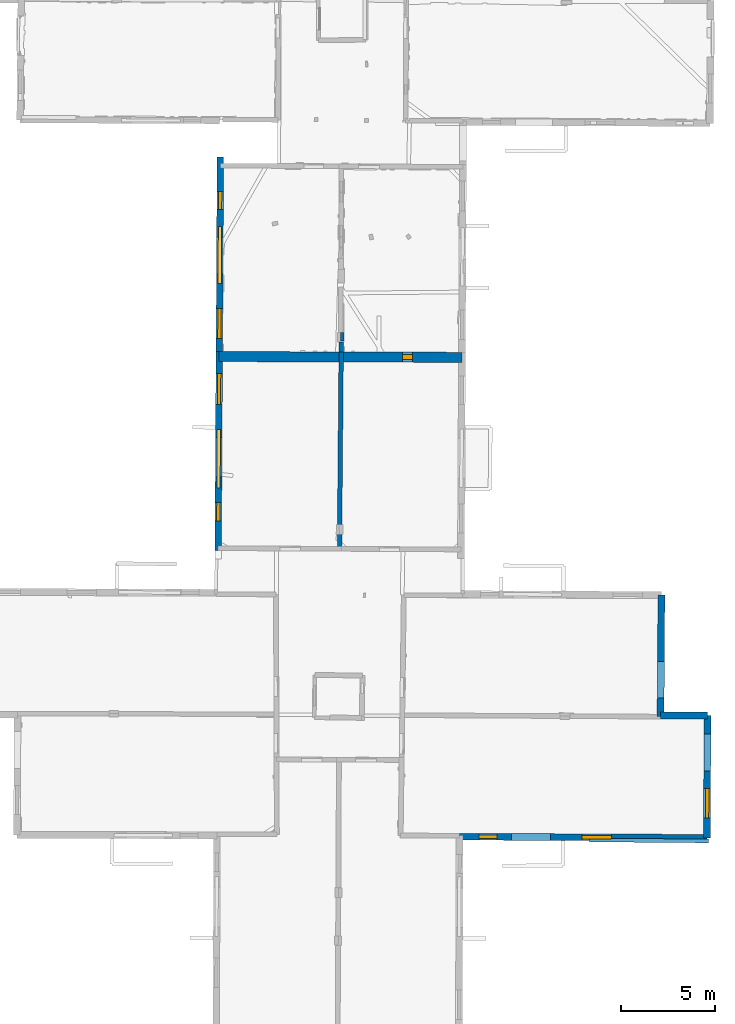
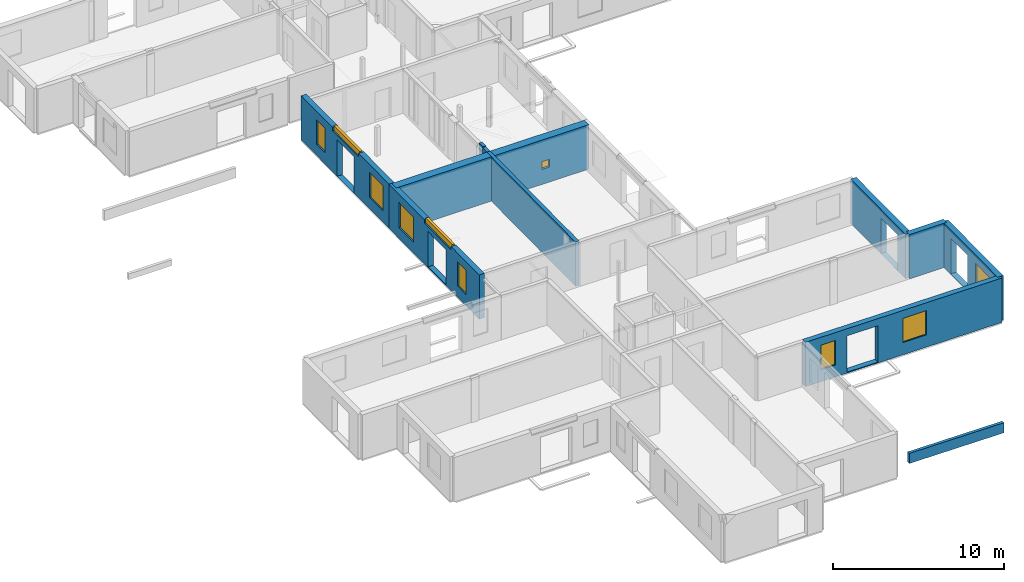
# One storey, part 6 of 17: 12 walls, 10 windows, 15 openings.
"""IFC2X3 building model written with IfcOpenShell, lengths in metres."""

from ifc_helpers import new_model, entity, si_unit, converted_unit, derived_unit, direction, frame, frame_2d, origin, origin_2d_with_axis, place, context, subcontext, project, spatial, polyline, rectangle, outline, extrude, source, transform, mapped, material, layer, layer_set, layer_usage, type_object, type_shapes, element, fill, save


model = new_model("IFC2X3")

# Units and contexts
model_context = context("Model", 3, precision=1e-05, world=origin(), true_north=direction((0.0, 1.0)))
body_context = subcontext(model_context, "Body", "Model", "MODEL_VIEW")
ifc_project = project(units=[si_unit("LENGTHUNIT", "METRE"), si_unit("AREAUNIT", "SQUARE_METRE"), si_unit("VOLUMEUNIT", "CUBIC_METRE"), converted_unit("PLANEANGLEUNIT", "DEGREE", entity("IfcRatioMeasure", 0.0174532925199433), si_unit("PLANEANGLEUNIT", "RADIAN"), dimensions=[0, 0, 0, 0, 0, 0, 0]), si_unit("MASSUNIT", "GRAM", prefix="KILO"), derived_unit("MASSDENSITYUNIT", [(si_unit("MASSUNIT", "GRAM", prefix="KILO"), 1), (si_unit("LENGTHUNIT", "METRE"), -3)]), derived_unit("MOMENTOFINERTIAUNIT", [(si_unit("LENGTHUNIT", "METRE"), 4)]), si_unit("TIMEUNIT", "SECOND"), si_unit("FREQUENCYUNIT", "HERTZ"), si_unit("THERMODYNAMICTEMPERATUREUNIT", "DEGREE_CELSIUS"), derived_unit("THERMALTRANSMITTANCEUNIT", [(si_unit("MASSUNIT", "GRAM", prefix="KILO"), 1), (si_unit("THERMODYNAMICTEMPERATUREUNIT", "KELVIN"), -1), (si_unit("TIMEUNIT", "SECOND"), -3)]), derived_unit("VOLUMETRICFLOWRATEUNIT", [(si_unit("LENGTHUNIT", "METRE"), 3), (si_unit("TIMEUNIT", "SECOND"), -1)]), si_unit("ELECTRICCURRENTUNIT", "AMPERE"), si_unit("ELECTRICVOLTAGEUNIT", "VOLT"), si_unit("POWERUNIT", "WATT"), si_unit("FORCEUNIT", "NEWTON", prefix="KILO"), si_unit("ILLUMINANCEUNIT", "LUX"), si_unit("LUMINOUSFLUXUNIT", "LUMEN"), si_unit("LUMINOUSINTENSITYUNIT", "CANDELA"), derived_unit("USERDEFINED", [(si_unit("MASSUNIT", "GRAM", prefix="KILO"), -1), (si_unit("LENGTHUNIT", "METRE"), -2), (si_unit("TIMEUNIT", "SECOND"), 3), (si_unit("LUMINOUSFLUXUNIT", "LUMEN"), 1)]), derived_unit("LINEARVELOCITYUNIT", [(si_unit("LENGTHUNIT", "METRE"), 1), (si_unit("TIMEUNIT", "SECOND"), -1)]), si_unit("PRESSUREUNIT", "PASCAL"), derived_unit("USERDEFINED", [(si_unit("LENGTHUNIT", "METRE"), -2), (si_unit("MASSUNIT", "GRAM", prefix="KILO"), 1), (si_unit("TIMEUNIT", "SECOND"), -2)]), derived_unit("LINEARFORCEUNIT", [(si_unit("MASSUNIT", "GRAM", prefix="KILO"), 1), (si_unit("LENGTHUNIT", "METRE"), 1), (si_unit("TIMEUNIT", "SECOND"), -2), (si_unit("LENGTHUNIT", "METRE"), -1)]), derived_unit("PLANARFORCEUNIT", [(si_unit("MASSUNIT", "GRAM", prefix="KILO"), 1), (si_unit("LENGTHUNIT", "METRE"), 1), (si_unit("TIMEUNIT", "SECOND"), -2), (si_unit("LENGTHUNIT", "METRE"), -2)])], contexts=[model_context])

# Site, building, storey
placement_1 = place(None, origin())
site = spatial("IfcSite", under=ifc_project, at=placement_1, CompositionType="ELEMENT")
building = spatial("IfcBuilding", under=site, at=placement_1, CompositionType="ELEMENT")
storey_placement = place(placement_1, frame((0.0, 0.0, 5.56662893295288)))
storey = spatial("IfcBuildingStorey", under=building, at=storey_placement, Name="Level 3", CompositionType="ELEMENT", Elevation=5.56662893295288)

# Wall, openings, windows
ifc_material_1 = material(Name="Default wall")
ifc_layer_1 = layer(ifc_material_1, 0.349999994039536)
ifc_layer_set_1 = layer_set([ifc_layer_1], Name="wall_thickness_0.3500")
ifc_layer_usage_1 = layer_usage(ifc_layer_set_1, "AXIS2", "POSITIVE", -0.174999997019768)
wall_type_1 = type_object("IfcWallType", Name="wall_thickness_0.3500", PredefinedType="STANDARD", material=ifc_layer_set_1)
wall_1_placement = place(storey_placement, frame((-0.148085783538035, 49.2356324303107, 0.0), z_axis=(0.0, 0.0, 1.0), x_axis=(-0.00565386337985013, -0.99998401678671, 0.0)))
wall_1 = element("IfcWallStandardCase", 1, at=wall_1_placement, inside=storey, type_object=wall_type_1, material=ifc_layer_usage_1, Name="Wall:12", ObjectType="Wall", context=body_context, shape_type="SweptSolid", body=[
    extrude(outline(polyline([(10.3857594121145, -0.174999997019768), (10.3857594121145, 0.174999997019768), (0.0, 0.174999997019768), (0.0, -0.174999997019768), (10.3857594121145, -0.174999997019768)])), origin(), (0.0, 0.0, 1.0), 3.16489877700806),
])
opening_1_placement = place(wall_1_placement, frame((4.25500041177543, -0.174999997019768, 0.00537109375)))
element("IfcOpeningElement", 2, at=opening_1_placement, cuts=wall_1, Name="Opening : 1985 x 2595 : 9", ObjectType="Opening", context=body_context, shape_type="SweptSolid", body=[
    extrude(rectangle(XDim=1.985, YDim=2.595, at=frame_2d((1.2975, 0.9925), x_axis=(0.0, 1.0))), frame((0.0, 0.0, 0.0), z_axis=(0.0, 1.0, 0.0), x_axis=(0.0, 0.0, 1.0)), (0.0, 0.0, 1.0), 0.349999994039536),
])
opening_2_placement = place(wall_1_placement, frame((8.08000127532441, -0.174999997019768, 0.820371150970459)))
opening_2 = element("IfcOpeningElement", 3, at=opening_2_placement, cuts=wall_1, Name="Opening : 1605 x 1790 : 10", ObjectType="Opening", context=body_context, shape_type="SweptSolid", body=[
    extrude(rectangle(XDim=1.605, YDim=1.79, at=frame_2d((0.895, 0.8025), x_axis=(0.0, 1.0))), frame((0.0, 0.0, 0.0), z_axis=(0.0, 1.0, 0.0), x_axis=(0.0, 0.0, 1.0)), (0.0, 0.0, 1.0), 0.349999994039536),
])
opening_3_placement = place(wall_1_placement, frame((1.83500171048367, -0.174999997019768, 0.810370922088623)))
opening_3 = element("IfcOpeningElement", 4, at=opening_3_placement, cuts=wall_1, Name="Opening : 965 x 1740 : 11", ObjectType="Opening", context=body_context, shape_type="SweptSolid", body=[
    extrude(rectangle(XDim=0.965, YDim=1.74, at=frame_2d((0.87, 0.4825), x_axis=(0.0, 1.0))), frame((0.0, 0.0, 0.0), z_axis=(0.0, 1.0, 0.0), x_axis=(0.0, 0.0, 1.0)), (0.0, 0.0, 1.0), 0.349999994039536),
])
opening_4_placement = place(wall_1_placement, frame((3.71000116138417, -0.174999997019768, 2.91537141799927)))
opening_4 = element("IfcOpeningElement", 5, at=opening_4_placement, cuts=wall_1, Name="Opening : 3050 x 340 : 12", ObjectType="Opening", context=body_context, shape_type="SweptSolid", body=[
    extrude(rectangle(XDim=3.05, YDim=0.34, at=frame_2d((0.17, 1.525), x_axis=(0.0, 1.0))), frame((0.0, 0.0, 0.0), z_axis=(0.0, 1.0, 0.0), x_axis=(0.0, 0.0, 1.0)), (0.0, 0.0, 1.0), 0.349999994039536),
])
ifc_material_2 = material(Name="Window Default")
window_style_1 = type_object("IfcWindowStyle", Name="Window : 1605 x 1790mm", ConstructionType="NOTDEFINED", OperationType="NOTDEFINED", ParameterTakesPrecedence=False, Sizeable=False, material=ifc_material_2)
shared_shape_1 = source(origin(), body_context, "Body", "SweptSolid", [
    extrude(rectangle(XDim=0.174999997019768, YDim=1.605, at=origin_2d_with_axis()), frame((0.8025, 0.174999997019768, 0.0), z_axis=(0.0, 0.0, 1.0), x_axis=(0.0, 1.0, 0.0)), (0.0, 0.0, 1.0), 1.79),
])
type_shapes(window_style_1, [shared_shape_1])
window_1_placement = place(opening_2_placement, origin())
window_1 = element("IfcWindow", 6, at=window_1_placement, inside=storey, type_object=window_style_1, Name="Window : 1605 x 1790mm : 4", ObjectType="Window : 1605 x 1790mm", OverallHeight=1.79, OverallWidth=1.605, context=body_context, shape_type="MappedRepresentation", body=[
    mapped(shared_shape_1, transform((0.0, 0.0, 0.0), scale=1.0)),
])
fill(opening_2, window_1)
window_style_2 = type_object("IfcWindowStyle", Name="Window : 965 x 1740mm", ConstructionType="NOTDEFINED", OperationType="NOTDEFINED", ParameterTakesPrecedence=False, Sizeable=False, material=ifc_material_2)
shared_shape_2 = source(origin(), body_context, "Body", "SweptSolid", [
    extrude(rectangle(XDim=0.174999997019768, YDim=0.965, at=origin_2d_with_axis()), frame((0.4825, 0.174999997019768, 0.0), z_axis=(0.0, 0.0, 1.0), x_axis=(0.0, 1.0, 0.0)), (0.0, 0.0, 1.0), 1.74),
])
type_shapes(window_style_2, [shared_shape_2])
window_2_placement = place(opening_3_placement, origin())
window_2 = element("IfcWindow", 7, at=window_2_placement, inside=storey, type_object=window_style_2, Name="Window : 965 x 1740mm : 5", ObjectType="Window : 965 x 1740mm", OverallHeight=1.74, OverallWidth=0.965, context=body_context, shape_type="MappedRepresentation", body=[
    mapped(shared_shape_2, transform((0.0, 0.0, 0.0), scale=1.0)),
])
fill(opening_3, window_2)
window_style_3 = type_object("IfcWindowStyle", Name="Window : 3050 x 340mm", ConstructionType="NOTDEFINED", OperationType="NOTDEFINED", ParameterTakesPrecedence=False, Sizeable=False, material=ifc_material_2)
shared_shape_3 = source(origin(), body_context, "Body", "SweptSolid", [
    extrude(rectangle(XDim=0.174999997019768, YDim=3.05, at=origin_2d_with_axis()), frame((1.525, 0.174999997019768, 0.0), z_axis=(0.0, 0.0, 1.0), x_axis=(0.0, 1.0, 0.0)), (0.0, 0.0, 1.0), 0.34),
])
type_shapes(window_style_3, [shared_shape_3])
window_3_placement = place(opening_4_placement, origin())
window_3 = element("IfcWindow", 8, at=window_3_placement, inside=storey, type_object=window_style_3, Name="Window : 3050 x 340mm : 6", ObjectType="Window : 3050 x 340mm", OverallHeight=0.34, OverallWidth=3.05, context=body_context, shape_type="MappedRepresentation", body=[
    mapped(shared_shape_3, transform((0.0, 0.0, 0.0), scale=1.0)),
])
fill(opening_4, window_3)

wall_2_placement = place(storey_placement, frame((-0.206805448350123, 38.850039016004, 0.0), z_axis=(0.0, 0.0, 1.0), x_axis=(-0.00565386274029306, -0.999984016790326, 0.0)))
wall_2 = element("IfcWallStandardCase", 9, at=wall_2_placement, inside=storey, type_object=wall_type_1, material=ifc_layer_usage_1, Name="Wall:13", ObjectType="Wall", context=body_context, shape_type="SweptSolid", body=[
    extrude(outline(polyline([(10.6344320573183, -0.174999997019768), (10.6344320573183, 0.174999997019768), (0.0, 0.174999997019768), (0.0, -0.174999997019768), (10.6344320573183, -0.174999997019768)])), origin(), (0.0, 0.0, 1.0), 3.16489877700806),
])
opening_5_placement = place(wall_2_placement, frame((4.59353731678375, -0.174999997019768, 0.073371410369873)))
element("IfcOpeningElement", 10, at=opening_5_placement, cuts=wall_2, Name="Opening : 2105 x 2510 : 13", ObjectType="Opening", context=body_context, shape_type="SweptSolid", body=[
    extrude(rectangle(XDim=2.105, YDim=2.51, at=frame_2d((1.255, 1.0525), x_axis=(0.0, 1.0))), frame((0.0, 0.0, 0.0), z_axis=(0.0, 1.0, 0.0), x_axis=(0.0, 0.0, 1.0)), (0.0, 0.0, 1.0), 0.349999994039536),
])
opening_6_placement = place(wall_2_placement, frame((1.16355466879029, -0.174999997019768, 0.783371448516846)))
opening_6 = element("IfcOpeningElement", 11, at=opening_6_placement, cuts=wall_2, Name="Opening : 1680 x 1785 : 14", ObjectType="Opening", context=body_context, shape_type="SweptSolid", body=[
    extrude(rectangle(XDim=1.68, YDim=1.785, at=frame_2d((0.8925, 0.84), x_axis=(0.0, 1.0))), frame((0.0, 0.0, 0.0), z_axis=(0.0, 1.0, 0.0), x_axis=(0.0, 0.0, 1.0)), (0.0, 0.0, 1.0), 0.349999994039536),
])
opening_7_placement = place(wall_2_placement, frame((4.15715949282285, -0.174999997019768, 2.92537069320679)))
opening_7 = element("IfcOpeningElement", 12, at=opening_7_placement, cuts=wall_2, Name="Opening : 3125 x 330 : 15", ObjectType="Opening", context=body_context, shape_type="SweptSolid", body=[
    extrude(rectangle(XDim=3.125, YDim=0.33, at=frame_2d((0.165, 1.5625), x_axis=(0.0, 1.0))), frame((0.0, 0.0, 0.0), z_axis=(0.0, 1.0, 0.0), x_axis=(0.0, 0.0, 1.0)), (0.0, 0.0, 1.0), 0.349999994039536),
])
opening_8_placement = place(wall_2_placement, frame((8.0642386942338, -0.174999997019768, 0.815371036529541)))
opening_8 = element("IfcOpeningElement", 13, at=opening_8_placement, cuts=wall_2, Name="Opening : 1000 x 1735 : 16", ObjectType="Opening", context=body_context, shape_type="SweptSolid", body=[
    extrude(rectangle(XDim=1.0, YDim=1.735, at=frame_2d((0.8675, 0.5), x_axis=(0.0, 1.0))), frame((0.0, 0.0, 0.0), z_axis=(0.0, 1.0, 0.0), x_axis=(0.0, 0.0, 1.0)), (0.0, 0.0, 1.0), 0.349999994039536),
])
window_style_4 = type_object("IfcWindowStyle", Name="Window : 1680 x 1785mm", ConstructionType="NOTDEFINED", OperationType="NOTDEFINED", ParameterTakesPrecedence=False, Sizeable=False, material=ifc_material_2)
shared_shape_4 = source(origin(), body_context, "Body", "SweptSolid", [
    extrude(rectangle(XDim=0.174999997019768, YDim=1.68, at=origin_2d_with_axis()), frame((0.84, 0.174999997019768, 0.0), z_axis=(0.0, 0.0, 1.0), x_axis=(0.0, 1.0, 0.0)), (0.0, 0.0, 1.0), 1.785),
])
type_shapes(window_style_4, [shared_shape_4])
window_4_placement = place(opening_6_placement, origin())
window_4 = element("IfcWindow", 14, at=window_4_placement, inside=storey, type_object=window_style_4, Name="Window : 1680 x 1785mm : 7", ObjectType="Window : 1680 x 1785mm", OverallHeight=1.785, OverallWidth=1.68, context=body_context, shape_type="MappedRepresentation", body=[
    mapped(shared_shape_4, transform((0.0, 0.0, 0.0), scale=1.0)),
])
fill(opening_6, window_4)
window_style_5 = type_object("IfcWindowStyle", Name="Window : 3125 x 330mm", ConstructionType="NOTDEFINED", OperationType="NOTDEFINED", ParameterTakesPrecedence=False, Sizeable=False, material=ifc_material_2)
shared_shape_5 = source(origin(), body_context, "Body", "SweptSolid", [
    extrude(rectangle(XDim=0.174999997019768, YDim=3.125, at=origin_2d_with_axis()), frame((1.5625, 0.174999997019768, 0.0), z_axis=(0.0, 0.0, 1.0), x_axis=(0.0, 1.0, 0.0)), (0.0, 0.0, 1.0), 0.33),
])
type_shapes(window_style_5, [shared_shape_5])
window_5_placement = place(opening_7_placement, origin())
window_5 = element("IfcWindow", 15, at=window_5_placement, inside=storey, type_object=window_style_5, Name="Window : 3125 x 330mm : 8", ObjectType="Window : 3125 x 330mm", OverallHeight=0.33, OverallWidth=3.125, context=body_context, shape_type="MappedRepresentation", body=[
    mapped(shared_shape_5, transform((0.0, 0.0, 0.0), scale=1.0)),
])
fill(opening_7, window_5)
window_style_6 = type_object("IfcWindowStyle", Name="Window : 1000 x 1735mm", ConstructionType="NOTDEFINED", OperationType="NOTDEFINED", ParameterTakesPrecedence=False, Sizeable=False, material=ifc_material_2)
shared_shape_6 = source(origin(), body_context, "Body", "SweptSolid", [
    extrude(rectangle(XDim=0.174999997019768, YDim=1.0, at=origin_2d_with_axis()), frame((0.5, 0.174999997019768, 0.0), z_axis=(0.0, 0.0, 1.0), x_axis=(0.0, 1.0, 0.0)), (0.0, 0.0, 1.0), 1.735),
])
type_shapes(window_style_6, [shared_shape_6])
window_6_placement = place(opening_8_placement, origin())
window_6 = element("IfcWindow", 16, at=window_6_placement, inside=storey, type_object=window_style_6, Name="Window : 1000 x 1735mm : 9", ObjectType="Window : 1000 x 1735mm", OverallHeight=1.735, OverallWidth=1.0, context=body_context, shape_type="MappedRepresentation", body=[
    mapped(shared_shape_6, transform((0.0, 0.0, 0.0), scale=1.0)),
])
fill(opening_8, window_6)

# Walls
ifc_layer_2 = layer(ifc_material_1, 0.2)
ifc_layer_set_2 = layer_set([ifc_layer_2], Name="wall_thickness_0.2000")
ifc_layer_usage_2 = layer_usage(ifc_layer_set_2, "AXIS2", "POSITIVE", -0.1)
wall_type_2 = type_object("IfcWallType", Name="wall_thickness_0.2000", PredefinedType="STANDARD", material=ifc_layer_set_2)
wall_3_placement = place(storey_placement, frame((6.36876383019679, 39.8704828800972, 0.0), z_axis=(0.0, 0.0, 1.0), x_axis=(0.000196954866562903, -0.99999998060439, 0.0)))
element("IfcWallStandardCase", 17, at=wall_3_placement, inside=storey, type_object=wall_type_2, material=ifc_layer_usage_2, Name="Wall:73", ObjectType="Wall", context=body_context, shape_type="SweptSolid", body=[
    extrude(outline(polyline([(0.459999093394619, -0.1), (0.459999093394619, 0.1), (0.0, 0.1), (0.0, -0.1), (0.459999093394619, -0.1)])), origin(), (0.0, 0.0, 1.0), 3.16489877700806),
])
placement_2 = place(placement_1, frame((0.0, 0.0, -2.2819995880127)))
wall_4_placement = place(placement_2, frame((19.5734389992916, 12.7478934471714, 0.0), z_axis=(0.0, 0.0, 1.0), x_axis=(0.999966804239949, -0.00814803155020282, 0.0)))
element("IfcWallStandardCase", 18, at=wall_4_placement, inside=storey, type_object=wall_type_2, material=ifc_layer_usage_2, Name="Wall:842", ObjectType="Wall", context=body_context, shape_type="SweptSolid", body=[
    extrude(outline(polyline([(6.35335650386325, -0.1), (6.35335650386325, 0.1), (0.0, 0.1), (0.0, -0.1), (6.35335650386325, -0.1)])), origin(), (0.0, 0.0, 1.0), 0.720746183395386),
])
ifc_layer_3 = layer(ifc_material_1, 0.239999994635582)
ifc_layer_set_3 = layer_set([ifc_layer_3], Name="wall_thickness_0.2400")
ifc_layer_usage_3 = layer_usage(ifc_layer_set_3, "AXIS2", "POSITIVE", -0.119999997317791)
wall_type_3 = type_object("IfcWallType", Name="wall_thickness_0.2400", PredefinedType="STANDARD", material=ifc_layer_set_3)
wall_5_placement = place(storey_placement, frame((6.31196838592047, 39.3572322556565, 0.0), z_axis=(0.0, 0.0, 1.0), x_axis=(-0.00862436004575228, -0.999962809515335, 0.0)))
element("IfcWallStandardCase", 19, at=wall_5_placement, inside=storey, type_object=wall_type_3, material=ifc_layer_usage_3, Name="Wall:24", ObjectType="Wall", context=body_context, shape_type="SweptSolid", body=[
    extrude(outline(polyline([(0.527351918381637, -0.119999997317791), (0.527351918381637, 0.119999997317791), (0.0, 0.119999997317791), (0.0, -0.119999997317791), (0.527351918381637, -0.119999997317791)])), origin(), (0.0, 0.0, 1.0), 3.16489877700806),
])
wall_6_placement = place(storey_placement, frame((6.30742031310553, 38.8298999497483, 0.0), z_axis=(0.0, 0.0, 1.0), x_axis=(-0.00862431246242064, -0.999962809925725, 0.0)))
element("IfcWallStandardCase", 20, at=wall_6_placement, inside=storey, type_object=wall_type_3, material=ifc_layer_usage_3, Name="Wall:25", ObjectType="Wall", context=body_context, shape_type="SweptSolid", body=[
    extrude(outline(polyline([(10.5242065510526, -0.119999997317791), (10.5242065510526, 0.119999997317791), (0.0, 0.119999997317791), (0.0, -0.119999997317791), (10.5242065510526, -0.119999997317791)])), origin(), (0.0, 0.0, 1.0), 3.16489877700806),
])
ifc_layer_4 = layer(ifc_material_1, 0.379999995231628)
ifc_layer_set_4 = layer_set([ifc_layer_4], Name="wall_thickness_0.3800")
ifc_layer_usage_4 = layer_usage(ifc_layer_set_4, "AXIS2", "POSITIVE", -0.189999997615814)
wall_type_4 = type_object("IfcWallType", Name="wall_thickness_0.3800", PredefinedType="STANDARD", material=ifc_layer_set_4)
wall_7_placement = place(storey_placement, frame((23.3757512405226, 19.3914861564153, 0.0), z_axis=(0.0, 0.0, 1.0), x_axis=(0.999997864009767, 0.00206687588011985, 0.0)))
element("IfcWallStandardCase", 21, at=wall_7_placement, inside=storey, type_object=wall_type_4, material=ifc_layer_usage_4, Name="Wall:16", ObjectType="Wall", context=body_context, shape_type="SweptSolid", body=[
    extrude(outline(polyline([(2.51006281081047, -0.189999997615814), (2.51006281081047, 0.189999997615814), (0.0, 0.189999997615814), (0.0, -0.189999997615814), (2.51006281081047, -0.189999997615814)])), origin(), (0.0, 0.0, 1.0), 3.16489877700806),
])

# Wall, opening
ifc_layer_5 = layer(ifc_material_1, 0.370000004768372)
ifc_layer_set_5 = layer_set([ifc_layer_5], Name="wall_thickness_0.3700")
ifc_layer_usage_5 = layer_usage(ifc_layer_set_5, "AXIS2", "POSITIVE", -0.185000002384186)
wall_type_5 = type_object("IfcWallType", Name="wall_thickness_0.3700", PredefinedType="STANDARD", material=ifc_layer_set_5)
wall_8_placement = place(storey_placement, frame((23.4187123764076, 25.8351452925577, 0.0), z_axis=(0.0, 0.0, 1.0), x_axis=(-0.00666684541583057, -0.999977776339155, 0.0)))
wall_8 = element("IfcWallStandardCase", 22, at=wall_8_placement, inside=storey, type_object=wall_type_5, material=ifc_layer_usage_5, Name="Wall:23", ObjectType="Wall", context=body_context, shape_type="SweptSolid", body=[
    extrude(outline(polyline([(6.49577843895644, -0.185000002384186), (6.49577843895644, 0.185000002384186), (0.0, 0.185000002384186), (0.0, -0.185000002384186), (6.49577843895644, -0.185000002384186)])), origin(), (0.0, 0.0, 1.0), 3.16489877700806),
])
opening_9_placement = place(wall_8_placement, frame((3.5532921171934, -0.185000002384186, 0.00537109375)))
element("IfcOpeningElement", 23, at=opening_9_placement, cuts=wall_8, Name="Opening : 1945 x 2550 : 24", ObjectType="Opening", context=body_context, shape_type="SweptSolid", body=[
    extrude(rectangle(XDim=1.945, YDim=2.55, at=frame_2d((1.275, 0.9725), x_axis=(0.0, 1.0))), frame((0.0, 0.0, 0.0), z_axis=(0.0, 1.0, 0.0), x_axis=(0.0, 0.0, 1.0)), (0.0, 0.0, 1.0), 0.370000004768372),
])

# Wall, openings, window
wall_9_placement = place(storey_placement, frame((25.8858095412571, 19.3966733384628, 0.0), z_axis=(0.0, 0.0, 1.0), x_axis=(-0.00573288330216395, -0.999983566889498, 0.0)))
wall_9 = element("IfcWallStandardCase", 24, at=wall_9_placement, inside=storey, type_object=wall_type_5, material=ifc_layer_usage_5, Name="Wall:101", ObjectType="Wall", context=body_context, shape_type="SweptSolid", body=[
    extrude(outline(polyline([(6.53196196996945, -0.185000002384186), (6.53196196996945, 0.185000002384186), (0.0, 0.185000002384186), (0.0, -0.185000002384186), (6.53196196996945, -0.185000002384186)])), origin(), (0.0, 0.0, 1.0), 3.16489877700806),
])
opening_10_placement = place(wall_9_placement, frame((0.983067495586276, -0.185000002384186, 0.0353708267211914)))
element("IfcOpeningElement", 25, at=opening_10_placement, cuts=wall_9, Name="Opening : 1970 x 2520 : 93", ObjectType="Opening", context=body_context, shape_type="SweptSolid", body=[
    extrude(rectangle(XDim=1.97, YDim=2.52, at=frame_2d((1.26, 0.985), x_axis=(0.0, 1.0))), frame((0.0, 0.0, 0.0), z_axis=(0.0, 1.0, 0.0), x_axis=(0.0, 0.0, 1.0)), (0.0, 0.0, 1.0), 0.370000004768372),
])
opening_11_placement = place(wall_9_placement, frame((3.89306748472566, -0.185000002384186, 0.870370864868164)))
opening_11 = element("IfcOpeningElement", 26, at=opening_11_placement, cuts=wall_9, Name="Opening : 1575 x 1685 : 94", ObjectType="Opening", context=body_context, shape_type="SweptSolid", body=[
    extrude(rectangle(XDim=1.575, YDim=1.685, at=frame_2d((0.8425, 0.7875), x_axis=(0.0, 1.0))), frame((0.0, 0.0, 0.0), z_axis=(0.0, 1.0, 0.0), x_axis=(0.0, 0.0, 1.0)), (0.0, 0.0, 1.0), 0.370000004768372),
])
window_style_7 = type_object("IfcWindowStyle", Name="Window : 1575 x 1685mm", ConstructionType="NOTDEFINED", OperationType="NOTDEFINED", ParameterTakesPrecedence=False, Sizeable=False, material=ifc_material_2)
shared_shape_7 = source(origin(), body_context, "Body", "SweptSolid", [
    extrude(rectangle(XDim=0.185000002384186, YDim=1.575, at=origin_2d_with_axis()), frame((0.7875, 0.185000002384186, 0.0), z_axis=(0.0, 0.0, 1.0), x_axis=(0.0, 1.0, 0.0)), (0.0, 0.0, 1.0), 1.685),
])
type_shapes(window_style_7, [shared_shape_7])
window_7_placement = place(opening_11_placement, origin())
window_7 = element("IfcWindow", 27, at=window_7_placement, inside=storey, type_object=window_style_7, Name="Window : 1575 x 1685mm : 54", ObjectType="Window : 1575 x 1685mm", OverallHeight=1.685, OverallWidth=1.575, context=body_context, shape_type="MappedRepresentation", body=[
    mapped(shared_shape_7, transform((0.0, 0.0, 0.0), scale=1.0)),
])
fill(opening_11, window_7)

# Wall, openings, windows
ifc_layer_6 = layer(ifc_material_1, 0.360000014305115)
ifc_layer_set_6 = layer_set([ifc_layer_6], Name="wall_thickness_0.3600")
ifc_layer_usage_6 = layer_usage(ifc_layer_set_6, "AXIS2", "POSITIVE", -0.180000007152557)
wall_type_6 = type_object("IfcWallType", Name="wall_thickness_0.3600", PredefinedType="STANDARD", material=ifc_layer_set_6)
wall_10_placement = place(storey_placement, frame((12.6366569276448, 12.9263607405436, 0.0), z_axis=(0.0, 0.0, 1.0), x_axis=(0.999989150854135, -0.00465812988499488, 0.0)))
wall_10 = element("IfcWallStandardCase", 28, at=wall_10_placement, inside=storey, type_object=wall_type_6, material=ifc_layer_usage_6, Name="Wall:103", ObjectType="Wall", context=body_context, shape_type="SweptSolid", body=[
    extrude(outline(polyline([(13.2118494987814, -0.180000007152557), (13.2118494987814, 0.180000007152557), (0.0, 0.180000007152557), (0.0, -0.180000007152557), (13.2118494987814, -0.180000007152557)])), origin(), (0.0, 0.0, 1.0), 3.16489877700806),
])
opening_12_placement = place(wall_10_placement, frame((2.78300445663802, -0.180000007152557, 0.0633711814880371)))
element("IfcOpeningElement", 29, at=opening_12_placement, cuts=wall_10, Name="Opening : 2070 x 2595 : 96", ObjectType="Opening", context=body_context, shape_type="SweptSolid", body=[
    extrude(rectangle(XDim=2.07, YDim=2.595, at=frame_2d((1.2975, 1.035), x_axis=(0.0, 1.0))), frame((0.0, 0.0, 0.0), z_axis=(0.0, 1.0, 0.0), x_axis=(0.0, 0.0, 1.0)), (0.0, 0.0, 1.0), 0.360000014305115),
])
opening_13_placement = place(wall_10_placement, frame((6.53368792106181, -0.180000007152557, 0.875370979309082)))
opening_13 = element("IfcOpeningElement", 30, at=opening_13_placement, cuts=wall_10, Name="Opening : 1580 x 1725 : 97", ObjectType="Opening", context=body_context, shape_type="SweptSolid", body=[
    extrude(rectangle(XDim=1.58, YDim=1.725, at=frame_2d((0.8625, 0.79), x_axis=(0.0, 1.0))), frame((0.0, 0.0, 0.0), z_axis=(0.0, 1.0, 0.0), x_axis=(0.0, 0.0, 1.0)), (0.0, 0.0, 1.0), 0.360000014305115),
])
opening_14_placement = place(wall_10_placement, frame((1.02368704591961, -0.180000007152557, 0.860371112823486)))
opening_14 = element("IfcOpeningElement", 31, at=opening_14_placement, cuts=wall_10, Name="Opening : 980 x 1740 : 98", ObjectType="Opening", context=body_context, shape_type="SweptSolid", body=[
    extrude(rectangle(XDim=0.98, YDim=1.74, at=frame_2d((0.87, 0.49), x_axis=(0.0, 1.0))), frame((0.0, 0.0, 0.0), z_axis=(0.0, 1.0, 0.0), x_axis=(0.0, 0.0, 1.0)), (0.0, 0.0, 1.0), 0.360000014305115),
])
window_style_8 = type_object("IfcWindowStyle", Name="Window : 1580 x 1725mm", ConstructionType="NOTDEFINED", OperationType="NOTDEFINED", ParameterTakesPrecedence=False, Sizeable=False, material=ifc_material_2)
shared_shape_8 = source(origin(), body_context, "Body", "SweptSolid", [
    extrude(rectangle(XDim=0.180000007152557, YDim=1.58, at=origin_2d_with_axis()), frame((0.79, 0.180000007152557, 0.0), z_axis=(0.0, 0.0, 1.0), x_axis=(0.0, 1.0, 0.0)), (0.0, 0.0, 1.0), 1.725),
])
type_shapes(window_style_8, [shared_shape_8])
window_8_placement = place(opening_13_placement, origin())
window_8 = element("IfcWindow", 32, at=window_8_placement, inside=storey, type_object=window_style_8, Name="Window : 1580 x 1725mm : 55", ObjectType="Window : 1580 x 1725mm", OverallHeight=1.725, OverallWidth=1.58, context=body_context, shape_type="MappedRepresentation", body=[
    mapped(shared_shape_8, transform((0.0, 0.0, 0.0), scale=1.0)),
])
fill(opening_13, window_8)
window_style_9 = type_object("IfcWindowStyle", Name="Window : 980 x 1740mm", ConstructionType="NOTDEFINED", OperationType="NOTDEFINED", ParameterTakesPrecedence=False, Sizeable=False, material=ifc_material_2)
shared_shape_9 = source(origin(), body_context, "Body", "SweptSolid", [
    extrude(rectangle(XDim=0.180000007152557, YDim=0.98, at=origin_2d_with_axis()), frame((0.49, 0.180000007152557, 0.0), z_axis=(0.0, 0.0, 1.0), x_axis=(0.0, 1.0, 0.0)), (0.0, 0.0, 1.0), 1.74),
])
type_shapes(window_style_9, [shared_shape_9])
window_9_placement = place(opening_14_placement, origin())
window_9 = element("IfcWindow", 33, at=window_9_placement, inside=storey, type_object=window_style_9, Name="Window : 980 x 1740mm : 56", ObjectType="Window : 980 x 1740mm", OverallHeight=1.74, OverallWidth=0.98, context=body_context, shape_type="MappedRepresentation", body=[
    mapped(shared_shape_9, transform((0.0, 0.0, 0.0), scale=1.0)),
])
fill(opening_14, window_9)

# Wall
ifc_layer_7 = layer(ifc_material_1, 0.540000021457672)
ifc_layer_set_7 = layer_set([ifc_layer_7], Name="wall_thickness_0.5400")
ifc_layer_usage_7 = layer_usage(ifc_layer_set_7, "AXIS2", "POSITIVE", -0.270000010728836)
wall_type_7 = type_object("IfcWallType", Name="wall_thickness_0.5400", PredefinedType="STANDARD", material=ifc_layer_set_7)
wall_11_placement = place(storey_placement, frame((-0.208334681361648, 38.5800456153877, 0.0), z_axis=(0.0, 0.0, 1.0), x_axis=(0.999994905300871, -0.00319207962027193, 0.0)))
element("IfcWallStandardCase", 34, at=wall_11_placement, inside=storey, type_object=wall_type_7, material=ifc_layer_usage_7, Name="Wall:113", ObjectType="Wall", context=body_context, shape_type="SweptSolid", body=[
    extrude(outline(polyline([(6.63492197508087, -0.270000010728836), (6.63492197508087, 0.270000010728836), (0.0, 0.270000010728836), (0.0, -0.270000010728836), (6.63492197508087, -0.270000010728836)])), origin(), (0.0, 0.0, 1.0), 3.16489877700806),
])

# Wall, opening, window
wall_12_placement = place(storey_placement, frame((6.42655349078801, 38.558866416169, 0.0), z_axis=(0.0, 0.0, 1.0), x_axis=(0.999994904364977, -0.00319237279794519, 0.0)))
wall_12 = element("IfcWallStandardCase", 35, at=wall_12_placement, inside=storey, type_object=wall_type_7, material=ifc_layer_usage_7, Name="Wall:114", ObjectType="Wall", context=body_context, shape_type="SweptSolid", body=[
    extrude(outline(polyline([(6.33796726682369, -0.270000010728836), (6.33796726682369, 0.270000010728836), (0.0, 0.270000010728836), (0.0, -0.270000010728836), (6.33796726682369, -0.270000010728836)])), origin(), (0.0, 0.0, 1.0), 3.16489877700806),
])
opening_15_placement = place(wall_12_placement, frame((3.17007291399, -0.270000010728836, 1.07037115097046)))
opening_15 = element("IfcOpeningElement", 36, at=opening_15_placement, cuts=wall_12, Name="Opening : 515 x 555 : 107", ObjectType="Opening", context=body_context, shape_type="SweptSolid", body=[
    extrude(rectangle(XDim=0.515, YDim=0.555, at=frame_2d((0.2775, 0.2575), x_axis=(0.0, 1.0))), frame((0.0, 0.0, 0.0), z_axis=(0.0, 1.0, 0.0), x_axis=(0.0, 0.0, 1.0)), (0.0, 0.0, 1.0), 0.540000021457672),
])
window_style_10 = type_object("IfcWindowStyle", Name="Window : 515 x 555mm", ConstructionType="NOTDEFINED", OperationType="NOTDEFINED", ParameterTakesPrecedence=False, Sizeable=False, material=ifc_material_2)
shared_shape_10 = source(origin(), body_context, "Body", "SweptSolid", [
    extrude(rectangle(XDim=0.270000010728836, YDim=0.515, at=origin_2d_with_axis()), frame((0.2575, 0.270000010728836, 0.0), z_axis=(0.0, 0.0, 1.0), x_axis=(0.0, 1.0, 0.0)), (0.0, 0.0, 1.0), 0.555),
])
type_shapes(window_style_10, [shared_shape_10])
window_10_placement = place(opening_15_placement, origin())
window_10 = element("IfcWindow", 37, at=window_10_placement, inside=storey, type_object=window_style_10, Name="Window : 515 x 555mm : 64", ObjectType="Window : 515 x 555mm", OverallHeight=0.555, OverallWidth=0.515, context=body_context, shape_type="MappedRepresentation", body=[
    mapped(shared_shape_10, transform((0.0, 0.0, 0.0), scale=1.0)),
])
fill(opening_15, window_10)

save(model, "model.ifc")
